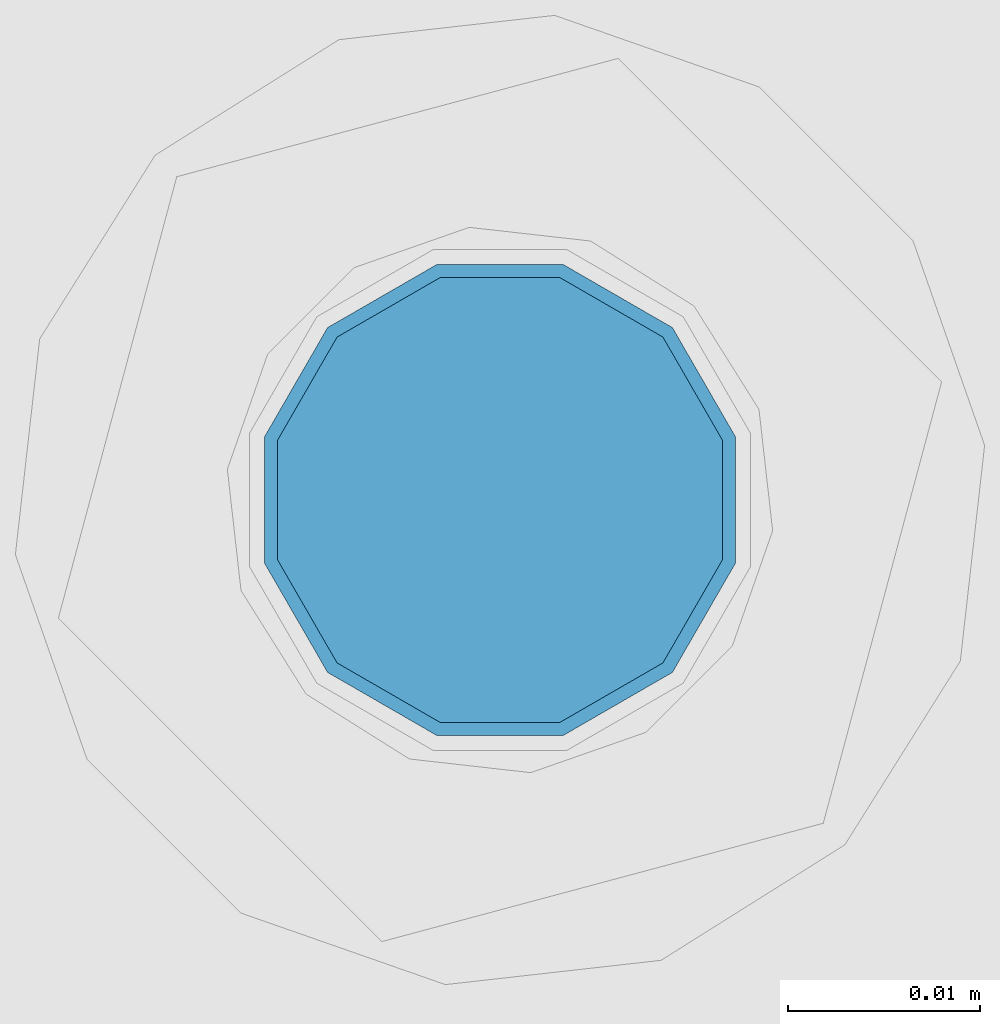
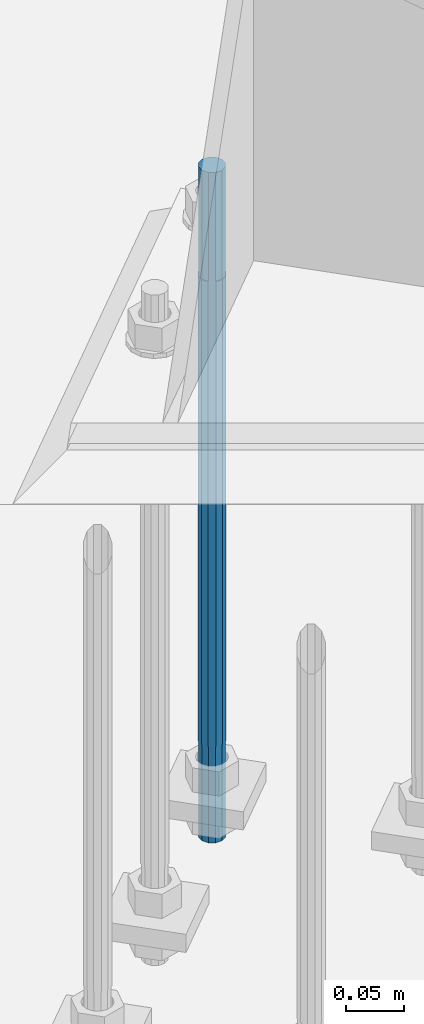
# One storey, part 812 of 1876: 1 column, 1 element without a shape of its own.
"""IFC2X3 building model written with IfcOpenShell, lengths in millimetres."""

from ifc_helpers import new_model, si_unit, frame, origin_with_axes, place, context, subcontext, project, spatial, faceted_brep, material, type_object, element, aggregate, save


model = new_model("IFC2X3")

# Units and contexts
model_context = context("Model", 3, precision=1e-05, world=origin_with_axes())
body_context = subcontext(model_context, "Body", "Model", "MODEL_VIEW")
ifc_project = project(units=[si_unit("LENGTHUNIT", "METRE", prefix="MILLI"), si_unit("AREAUNIT", "SQUARE_METRE"), si_unit("VOLUMEUNIT", "CUBIC_METRE"), si_unit("MASSUNIT", "GRAM", prefix="KILO"), si_unit("TIMEUNIT", "SECOND"), si_unit("PLANEANGLEUNIT", "RADIAN"), si_unit("SOLIDANGLEUNIT", "STERADIAN"), si_unit("THERMODYNAMICTEMPERATUREUNIT", "DEGREE_CELSIUS"), si_unit("LUMINOUSINTENSITYUNIT", "LUMEN")], contexts=[model_context])

# Site, building, storey
site_placement = place(None, origin_with_axes())
site = spatial("IfcSite", under=ifc_project, at=site_placement, CompositionType="ELEMENT")
building_placement = place(site_placement, origin_with_axes())
building = spatial("IfcBuilding", under=site, at=building_placement, Name="Undefined", CompositionType="ELEMENT")
storey_placement = place(building_placement, origin_with_axes())
storey = spatial("IfcBuildingStorey", under=building, at=storey_placement, Name="Undefined", CompositionType="ELEMENT", Elevation=0.0)

# Assembly, column
assembly_placement = place(storey_placement, origin_with_axes())
assembly = element("IfcElementAssembly", 1, at=assembly_placement, inside=storey, Name="TEMPLATE", AssemblyPlace="NOTDEFINED", PredefinedType="RIGID_FRAME")
ifc_material = material(Name="STEEL/F1554-GR.105")
column_type = type_object("IfcColumnType", PredefinedType="NOTDEFINED")
column_placement = place(assembly_placement, frame((6580.27820529301, -7869.6174255113, 7.105427357601e-15), z_axis=(-0.707106781186547, -0.707106781186548, 0.0), x_axis=(0.0, 0.0, -1.0)))
column = element("IfcColumn", 2, at=column_placement, type_object=column_type, material=ifc_material, Name="ANCHOR_BOLTS", context=body_context, shape_type="Brep", body=[
    faceted_brep([(-114.3, -10.3923048454853, 6.0000000001337), (-114.3, -6.00000000006912, 10.3923048455481), (-114.3, -6.54836185276508e-11, 12.0000000001355), (-114.3, 5.99999999993634, 10.3923048455481), (-114.3, 10.3923048453526, 6.00000000013279), (-114.3, 11.9999999999418, 1.29148247651756e-10), (-114.3, 10.3923048453507, -5.99999999987358), (-114.3, 5.99999999993815, -10.392304845288), (-114.3, -6.54836185276508e-11, -11.9999999998781), (-114.3, -6.00000000006912, -10.3923048452889), (-114.3, -10.3923048454853, -5.99999999987358), (-114.3, -12.0000000000728, 1.28238752949983e-10), (0.0, 11.9999999999418, 1.29148247651756e-10), (0.0, 10.3923048453507, -5.99999999987358), (0.0, 5.99999999993815, -10.392304845288), (0.0, -6.54836185276508e-11, -11.9999999998781), (0.0, -6.00000000006912, -10.3923048452889), (0.0, -10.3923048454853, -5.99999999987358), (0.0, -12.0000000000728, 1.28238752949983e-10), (0.0, -10.3923048454853, 6.0000000001337), (0.0, -6.00000000006912, 10.3923048455481), (0.0, -6.54836185276508e-11, 12.0000000001355), (0.0, 5.99999999993634, 10.3923048455481), (0.0, 10.3923048453526, 6.00000000013279), (0.0, -10.998522628066, 6.35000000000218), (0.0, -6.35000000000218, 10.9985226280642), (0.0, 0.0, 12.7000000000035), (0.0, 6.34999999999854, 10.9985226280651), (0.0, 10.9985226280623, 6.35000000000218), (0.0, 12.6999999999998, 0.0), (0.0, 10.9985226280623, -6.35000000000127), (0.0, 6.34999999999854, -10.9985226280633), (0.0, 0.0, -12.7000000000016), (0.0, -6.35000000000218, -10.9985226280642), (0.0, -10.998522628066, -6.35000000000127), (0.0, -12.6999999999998, 0.0), (488.95, -12.7000000000044, 9.09494701772928e-13), (488.95, -10.998522628066, 6.35000000000218), (488.95, -6.35000000000218, 10.9985226280642), (488.95, 0.0, 12.7000000000035), (488.95, 6.34999999999854, 10.9985226280651), (488.95, 10.9985226280623, 6.35000000000218), (488.95, 12.7000000000007, 9.09494701772928e-13), (488.95, 10.9985226280623, -6.35000000000127), (488.95, 6.34999999999854, -10.9985226280633), (488.95, 0.0, -12.7000000000016), (488.95, -6.35000000000218, -10.9985226280642), (488.95, -10.998522628066, -6.35000000000127), (488.95, -6.00000000006912, 10.3923048455481), (488.95, -6.54836185276508e-11, 12.0000000001355), (488.95, 5.99999999993634, 10.3923048455481), (488.95, 10.3923048453526, 6.00000000013279), (488.95, 11.9999999999418, 1.29148247651756e-10), (488.95, 10.3923048453507, -5.99999999987358), (488.95, 5.99999999993815, -10.392304845288), (488.95, -6.54836185276508e-11, -11.9999999998781), (488.95, -6.00000000006912, -10.3923048452889), (488.95, -10.3923048454853, -5.99999999987358), (488.95, -12.0000000000728, 1.28238752949983e-10), (488.95, -10.3923048454853, 6.0000000001337), (590.55, -6.00000000006912, -10.3923048452889), (590.55, -6.54836185276508e-11, -11.9999999998781), (590.55, 5.99999999993815, -10.392304845288), (590.55, 10.3923048453507, -5.99999999987358), (590.55, 11.9999999999418, 1.29148247651756e-10), (590.55, 10.3923048453526, 6.00000000013279), (590.55, 5.99999999993634, 10.3923048455481), (590.55, -6.54836185276508e-11, 12.0000000001355), (590.55, -6.00000000006912, 10.3923048455481), (590.55, -10.3923048454853, 6.0000000001337), (590.55, -12.0000000000728, 1.28238752949983e-10), (590.55, -10.3923048454853, -5.99999999987358)], [[[0, 1, 2, 3, 4, 5, 6, 7, 8, 9, 10, 11]], [[6, 5, 12, 13]], [[7, 6, 13, 14]], [[8, 7, 14, 15]], [[9, 8, 15, 16]], [[10, 9, 16, 17]], [[11, 10, 17, 18]], [[0, 11, 18, 19]], [[1, 0, 19, 20]], [[2, 1, 20, 21]], [[3, 2, 21, 22]], [[4, 3, 22, 23]], [[5, 4, 23, 12]], [[24, 25, 26, 27, 28, 29, 30, 31, 32, 33, 34, 35], [22, 21, 20, 19, 18, 17, 16, 15, 14, 13, 12, 23]], [[24, 35, 36, 37]], [[25, 24, 37, 38]], [[26, 25, 38, 39]], [[27, 26, 39, 40]], [[28, 27, 40, 41]], [[29, 28, 41, 42]], [[30, 29, 42, 43]], [[31, 30, 43, 44]], [[32, 31, 44, 45]], [[33, 32, 45, 46]], [[34, 33, 46, 47]], [[35, 34, 47, 36]], [[46, 45, 44, 43, 42, 41, 40, 39, 38, 37, 36, 47], [48, 49, 50, 51, 52, 53, 54, 55, 56, 57, 58, 59]], [[60, 61, 62, 63, 64, 65, 66, 67, 68, 69, 70, 71]], [[68, 67, 49, 48]], [[69, 68, 48, 59]], [[70, 69, 59, 58]], [[71, 70, 58, 57]], [[60, 71, 57, 56]], [[61, 60, 56, 55]], [[62, 61, 55, 54]], [[63, 62, 54, 53]], [[64, 63, 53, 52]], [[65, 64, 52, 51]], [[66, 65, 51, 50]], [[67, 66, 50, 49]]]),
])
aggregate(assembly, [column])

save(model, "model.ifc")
